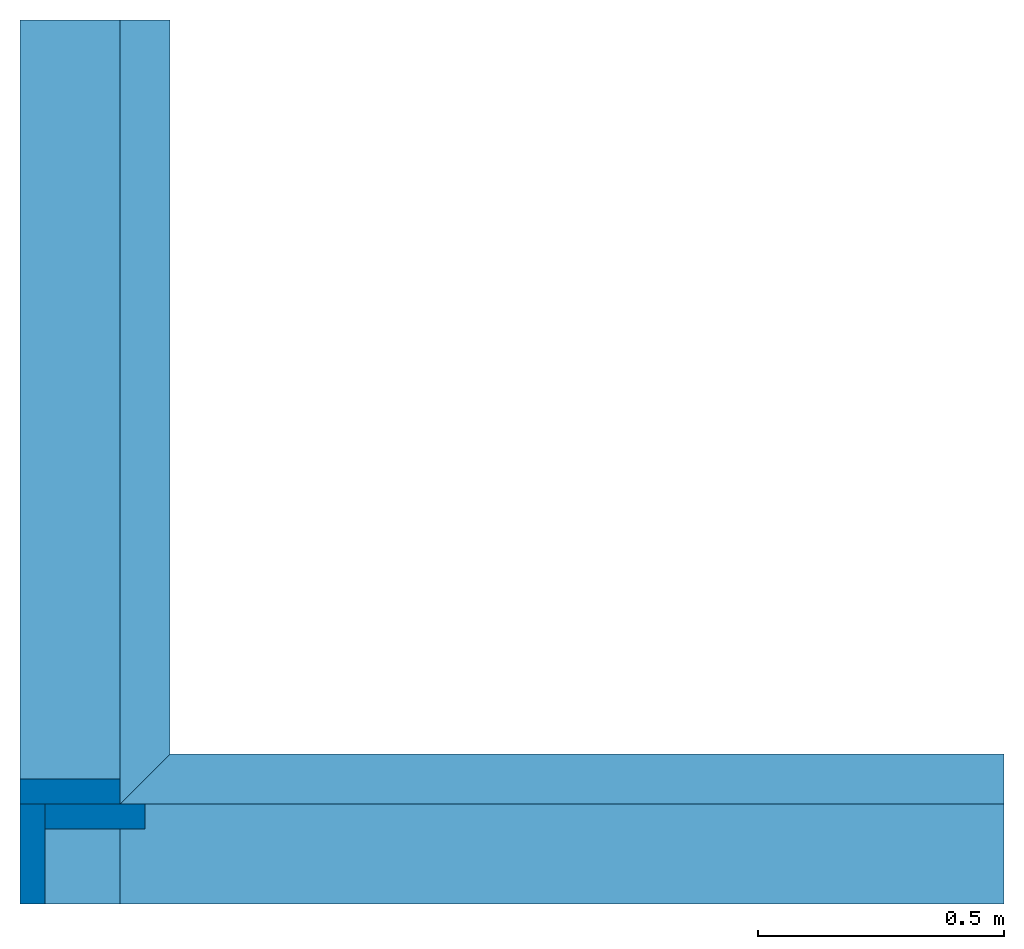
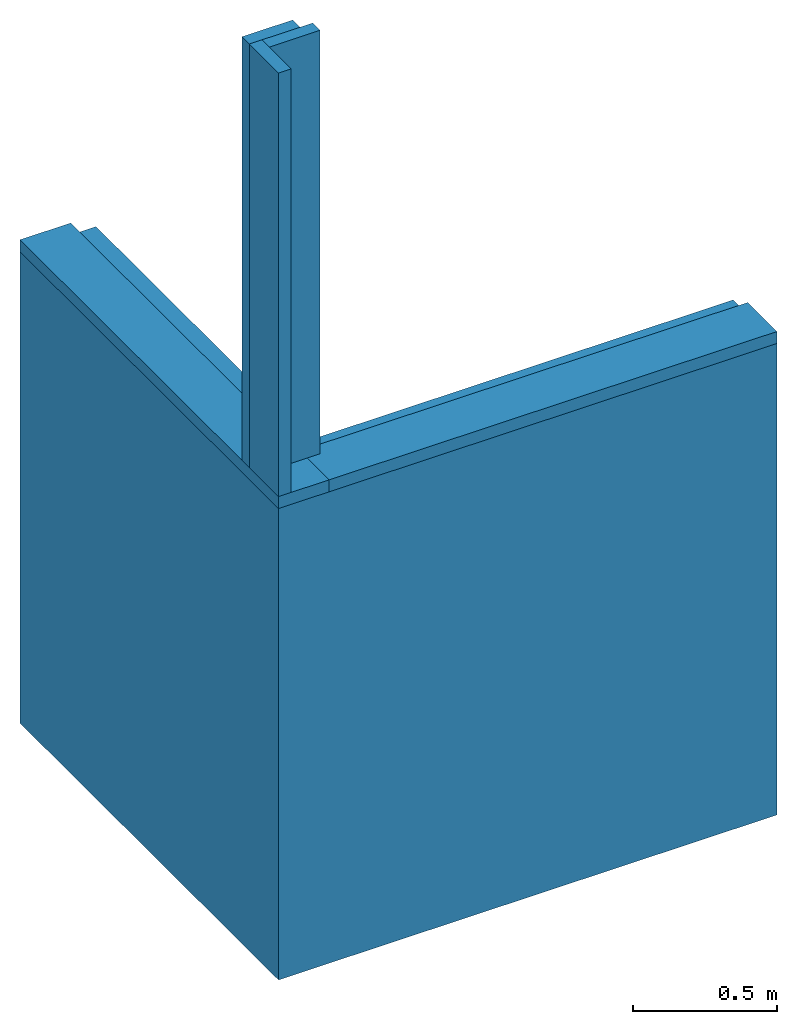
# One storey: 7 walls.
"""IFC4 building model written with IfcOpenShell, lengths in inches."""

from ifc_helpers import new_model, entity, si_unit, converted_unit, frame, frame_2d, origin_with_axes, place, context, subcontext, project, spatial, polygons, material, element, save


model = new_model("IFC4")

# Units and contexts
model_context = context("Model", 3, precision=1e-05, world=origin_with_axes())
plan_context = context("Plan", 2, precision=1e-05, world=frame_2d((0.0, 0.0, 0.0), x_axis=(1.0, 0.0, 0.0)))
body_context = subcontext(model_context, "Body", "Model", "MODEL_VIEW")
ifc_project = project(units=[converted_unit("AREAUNIT", "square inch", entity("IfcReal", 0.0006452), si_unit("AREAUNIT", "SQUARE_METRE"), dimensions=[2, 0, 0, 0, 0, 0, 0]), converted_unit("LENGTHUNIT", "inch", entity("IfcReal", 0.0254), si_unit("LENGTHUNIT", "METRE"), dimensions=[1, 0, 0, 0, 0, 0, 0]), converted_unit("VOLUMEUNIT", "cubic inch", entity("IfcReal", 1.639e-05), si_unit("VOLUMEUNIT", "CUBIC_METRE"), dimensions=[3, 0, 0, 0, 0, 0, 0])], contexts=[model_context, plan_context])

# Site, building, storey
site_placement = place(None, origin_with_axes())
site = spatial("IfcSite", under=ifc_project, at=site_placement)
building_placement = place(site_placement, origin_with_axes())
building = spatial("IfcBuilding", under=site, at=building_placement, Name="Building")
storey_placement = place(building_placement, origin_with_axes())
storey = spatial("IfcBuildingStorey", under=building, at=storey_placement, Name="Storey")

# Walls
ifc_material = material(Name="Concrete")
wall_1_placement = place(storey_placement, frame((0.18779217727541, 0.204054389412948, 0.0), z_axis=(0.0, 0.0, 1.0), x_axis=(1.0, 0.0, 0.0)))
element("IfcWall", 1, at=wall_1_placement, inside=storey, material=ifc_material, PredefinedType="ELEMENTEDWALL", context=body_context, shape_type="Tessellation", body=[
    polygons([(78.7401580810547, 0.0, 0.0), (-1.17331978799484e-06, 0.0, 0.0), (78.7401580810547, 0.0, 78.7401580810547), (-1.17331978799484e-06, 0.0, 78.7401580810547), (78.7401580810547, 12.0000009536743, 0.0), (12.0, 12.0000009536743, 0.0), (78.7401580810547, 12.0000009536743, 78.7401580810547), (12.0, 12.0000009536743, 78.7401580810547)], [[[2, 1, 3, 4]], [[6, 8, 7, 5]], [[2, 4, 8, 6]], [[1, 2, 6, 5]], [[4, 3, 7, 8]], [[3, 1, 5, 7]]]),
])
wall_2_placement = place(storey_placement, frame((12.1877946722226, 0.204054389412948, -1.17331977904312e-06), z_axis=(0.0, 0.0, 1.0), x_axis=(-1.62920684942947e-07, 1.0, 0.0)))
element("IfcWall", 2, at=wall_2_placement, inside=storey, PredefinedType="ELEMENTEDWALL", context=body_context, shape_type="Tessellation", body=[
    polygons([(12.0000028610229, 6.39863571905153e-07, 0.0), (12.0000028610229, 6.39863571905153e-07, 78.7401580810547), (1.17331978799484e-06, 12.0000028610229, 0.0), (1.17331978799484e-06, 12.0000028610229, 78.7401580810547), (70.7401580810547, 1.17331978799484e-06, 78.7401580810547), (70.7401580810547, 1.17331978799484e-06, 0.0), (70.7401580810547, 12.0000028610229, 78.7401580810547), (70.7401580810547, 12.0000028610229, 0.0)], [[[1, 6, 5, 2]], [[3, 4, 7, 8]], [[1, 2, 4, 3]], [[6, 1, 3, 8]], [[2, 5, 7, 4]], [[5, 6, 8, 7]]]),
])
for number, where, z_axis, x_axis in (
    (3, (8.18779325391364, -7.79594492724561, -56.9757514112578), (0.0, 0.0, 1.0), (-4.37113882867379e-08, 1.0, 0.0)),
    (4, (137.903699724693, 0.204053802753058, 72.740147432943), (-1.0, 0.0, 7.54979012640433e-08), (7.54979012640433e-08, 0.0, 1.0)),
):
    element("IfcWall", number, at=place(storey_placement, frame(where, z_axis=z_axis, x_axis=x_axis)), inside=storey, PredefinedType="ELEMENTEDWALL", context=body_context, shape_type="Tessellation", body=[
        polygons([(78.7401580810547, 0.0, 135.715911865234), (78.7401580810547, 0.0, 137.715911865234), (78.7401580810547, 8.00000095367432, 135.715911865234), (78.7401580810547, 8.00000095367432, 137.715911865234), (8.0, 0.0, 135.715911865234), (8.0, 8.00000095367432, 135.715911865234), (8.0, 0.0, 137.715911865234), (8.0, 8.00000095367432, 137.715911865234)], [[[6, 3, 1, 5]], [[7, 2, 4, 8]], [[5, 1, 2, 7]], [[1, 3, 4, 2]], [[3, 6, 8, 4]], [[6, 5, 7, 8]]]),
    ])
for number, where, z_axis, x_axis in (
    (5, (0.187791003955631, 8.20405546605118, 80.7401608294389), (4.37113882867379e-08, -1.0, -5.21253117251541e-16), (1.19248806385031e-08, 0.0, 1.0)),
    (6, (2.18779435307961, 6.2040521169272, 80.7401514428807), (4.37113882867379e-08, -1.0, -5.21253117251541e-16), (1.19248806385031e-08, 0.0, 1.0)),
):
    element("IfcWall", number, at=place(storey_placement, frame(where, z_axis=z_axis, x_axis=x_axis)), inside=storey, PredefinedType="ELEMENTEDWALL", context=body_context, shape_type="Tessellation", body=[
        polygons([(70.7401580810547, -8.00000190734863, -2.00000333786011), (70.7401580810547, -8.00000190734863, 0.0), (70.7401580810547, -5.86659893997421e-07, -2.00000333786011), (70.7401580810547, -5.86659893997421e-07, 0.0), (0.0, -8.00000190734863, -2.00000333786011), (0.0, -5.86659893997421e-07, -2.00000333786011), (0.0, -8.00000190734863, 0.0), (0.0, -5.86659893997421e-07, 0.0)], [[[6, 3, 1, 5]], [[7, 2, 4, 8]], [[5, 1, 2, 7]], [[1, 3, 4, 2]], [[3, 6, 8, 4]], [[6, 5, 7, 8]]]),
    ])
wall_3_placement = place(storey_placement, origin_with_axes())
element("IfcWall", 7, at=wall_3_placement, inside=storey, PredefinedType="ELEMENTEDWALL", context=body_context, shape_type="Tessellation", body=[
    polygons([(8.18779182434082, 0.204054981470108, 78.7401580810547), (8.18779182434082, 8.20405578613281, 78.7401580810547), (78.9279479980469, 8.20405578613281, 78.7401504516602), (78.9279479980469, 0.204054981470108, 78.7401504516602), (8.18779182434082, 0.204054981470108, 80.7401580810547), (8.18779182434082, 8.20405578613281, 80.7401580810547), (78.9279479980469, 0.204054981470108, 80.7401504516602), (78.9279479980469, 8.20405578613281, 80.7401504516602)], [[[1, 5, 6, 2]], [[5, 7, 8, 6]], [[4, 1, 2, 3]], [[3, 8, 7, 4]], [[2, 6, 8, 3]], [[4, 7, 5, 1]]]),
])

save(model, "model.ifc")
